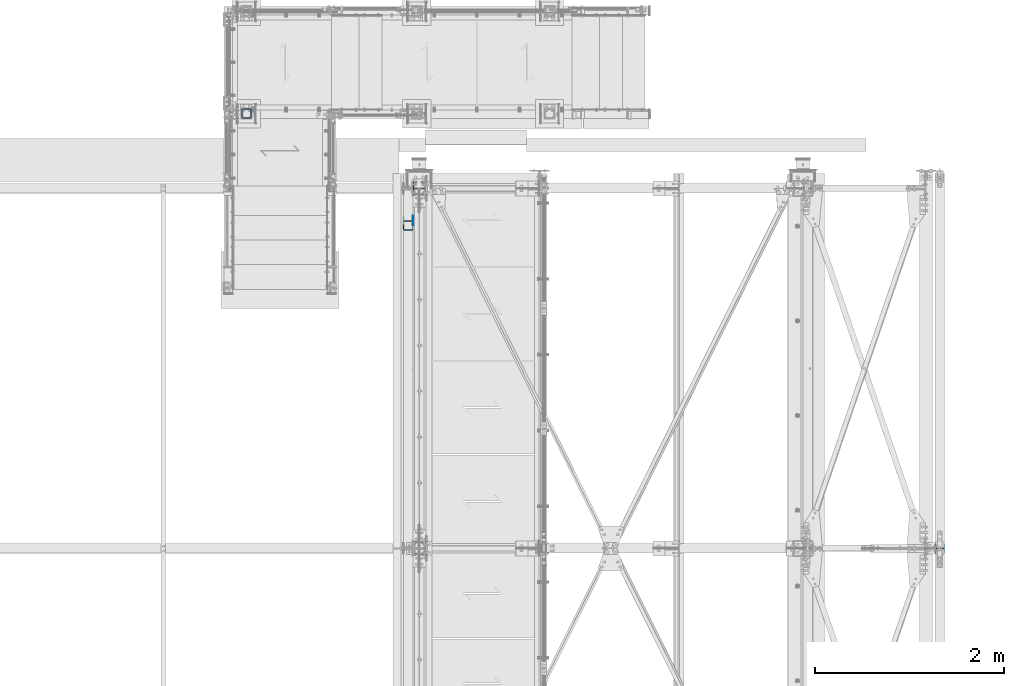
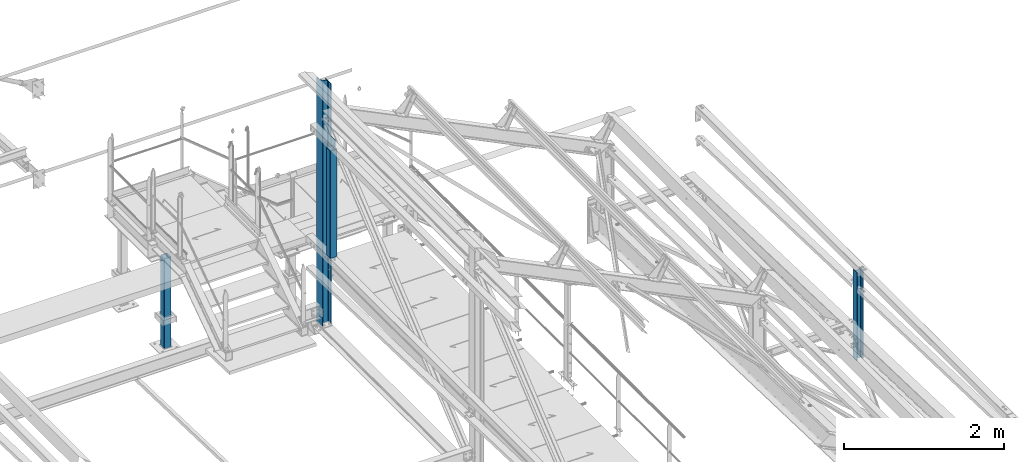
# One storey, part 18 of 496: 5 columns, 4 elements without a shape of their own.
"""IFC2X3 building model written with IfcOpenShell, lengths in millimetres."""

from ifc_helpers import new_model, si_unit, frame, origin_with_axes, origin_2d_with_axis, place, context, subcontext, project, spatial, rectangle, hollow_rectangle, i_section, extrude, clip, halfspace, material, type_object, element, aggregate, save


model = new_model("IFC2X3")

# Units and contexts
model_context = context("Model", 3, precision=1e-05, world=origin_with_axes())
body_context = subcontext(model_context, "Body", "Model", "MODEL_VIEW")
ifc_project = project(units=[si_unit("LENGTHUNIT", "METRE", prefix="MILLI"), si_unit("AREAUNIT", "SQUARE_METRE"), si_unit("VOLUMEUNIT", "CUBIC_METRE"), si_unit("MASSUNIT", "GRAM", prefix="KILO"), si_unit("TIMEUNIT", "SECOND"), si_unit("PLANEANGLEUNIT", "RADIAN"), si_unit("SOLIDANGLEUNIT", "STERADIAN"), si_unit("THERMODYNAMICTEMPERATUREUNIT", "DEGREE_CELSIUS"), si_unit("LUMINOUSINTENSITYUNIT", "LUMEN")], contexts=[model_context])

# Site, building, storey
site_placement = place(None, origin_with_axes())
site = spatial("IfcSite", under=ifc_project, at=site_placement, CompositionType="ELEMENT")
building_placement = place(site_placement, origin_with_axes())
building = spatial("IfcBuilding", under=site, at=building_placement, Name="Undefined", CompositionType="ELEMENT")
storey_placement = place(building_placement, origin_with_axes())
storey = spatial("IfcBuildingStorey", under=building, at=storey_placement, Name="Undefined", CompositionType="ELEMENT", Elevation=0.0)

# Assembly, column
assembly_1_placement = place(storey_placement, origin_with_axes())
assembly_1 = element("IfcElementAssembly", 1, at=assembly_1_placement, inside=storey, AssemblyPlace="NOTDEFINED", PredefinedType="NOTDEFINED")
ifc_material_1 = material(Name="Undefined/S235-E24")
column_type_1 = type_object("IfcColumnType", PredefinedType="NOTDEFINED")
column_1_placement = place(assembly_1_placement, frame((32455.0000000001, 15989.9999136253, 7062.0), z_axis=(0.0, 0.0, 1.0), x_axis=(0.0, 1.0, 0.0)))
column_1 = element("IfcColumn", 2, at=column_1_placement, type_object=column_type_1, material=ifc_material_1, context=body_context, shape_type="SweptSolid", body=[
    extrude(hollow_rectangle(XDim=100.0, YDim=100.0, WallThickness=5.0, InnerFilletRadius=5.0, OuterFilletRadius=10.0, at=origin_2d_with_axis()), frame((0.0, 0.0, 1370.00011661134), z_axis=(0.0, 0.0, -1.0), x_axis=(0.0, 1.0, 0.0)), (0.0, 0.0, 1.0), 1370.0),
])
aggregate(assembly_1, [column_1])

assembly_2_placement = place(storey_placement, origin_with_axes())
assembly_2 = element("IfcElementAssembly", 3, at=assembly_2_placement, inside=storey, Name="MONTANT", AssemblyPlace="NOTDEFINED", PredefinedType="NOTDEFINED")
column_type_2 = type_object("IfcColumnType", PredefinedType="NOTDEFINED")
column_2_placement = place(assembly_2_placement, frame((34163.5000106229, 14810.0001581517, 8555.00000000001), z_axis=(0.0, 0.0, 1.0), x_axis=(0.0, 1.0, 0.0)))
column_2 = element("IfcColumn", 4, at=column_2_placement, type_object=column_type_2, material=ifc_material_1, Name="MONTANT", context=body_context, shape_type="SweptSolid", body=[
    extrude(hollow_rectangle(XDim=100.0, YDim=100.0, WallThickness=4.0, InnerFilletRadius=4.0, OuterFilletRadius=8.0, at=origin_2d_with_axis()), frame((0.0, 0.0, 1635.0), z_axis=(0.0, 0.0, -1.0), x_axis=(0.0, 1.0, 0.0)), (0.0, 0.0, 1.0), 1635.0),
])

assembly_3_placement = place(storey_placement, origin_with_axes())
assembly_3 = element("IfcElementAssembly", 5, at=assembly_3_placement, inside=storey, Name="MONTANT", AssemblyPlace="NOTDEFINED", PredefinedType="NOTDEFINED")
ifc_material_2 = material(Name="Undefined/S275-E28")
column_type_3 = type_object("IfcColumnType", Name="HEA140", PredefinedType="NOTDEFINED")
column_3_placement = place(assembly_3_placement, frame((34280.0, 15200.0, 7260.0), z_axis=(0.0, 0.0, 1.0), x_axis=(-1.0, 0.0, 0.0)))
column_3 = element("IfcColumn", 6, at=column_3_placement, type_object=column_type_3, material=ifc_material_2, Name="MONTANT", ObjectType="HEA140", context=body_context, shape_type="Clipping", body=[
    clip(extrude(i_section(OverallWidth=140.0, OverallDepth=133.0, WebThickness=5.5, FlangeThickness=8.5, FilletRadius=12.0, at=origin_2d_with_axis()), frame((0.0, 0.0, 3730.84210522584), z_axis=(0.0, 0.0, -1.0), x_axis=(0.0, 1.0, 0.0)), (0.0, 0.0, 1.0), 3730.84), halfspace(frame((-66.5, 70.0, 3654.3071165161), z_axis=(-0.441220937981244, -6.28179308850765e-09, 0.89739850896185), x_axis=(0.89739850896185, 0.0, 0.441220937981244)), False)),
])
aggregate(assembly_3, [column_3])

assembly_4_placement = place(storey_placement, origin_with_axes())
assembly_4 = element("IfcElementAssembly", 7, at=assembly_4_placement, inside=storey, AssemblyPlace="NOTDEFINED", PredefinedType="NOTDEFINED")
column_type_4 = type_object("IfcColumnType", Name="HEA100", PredefinedType="NOTDEFINED")
column_4_placement = place(assembly_4_placement, frame((39777.0, 11399.9999999731, 7100.00252984107), z_axis=(0.0, 0.0, 1.0), x_axis=(1.0, 0.0, 0.0)))
column_4 = element("IfcColumn", 8, at=column_4_placement, type_object=column_type_4, material=ifc_material_2, ObjectType="HEA100", context=body_context, shape_type="SweptSolid", body=[
    extrude(i_section(OverallWidth=100.0, OverallDepth=96.0, WebThickness=5.0, FlangeThickness=8.0, FilletRadius=12.0, at=origin_2d_with_axis()), frame((0.0, 0.0, 1344.99747015972), z_axis=(0.0, 0.0, -1.0), x_axis=(0.0, 1.0, 0.0)), (0.0, 0.0, 1.0), 1345.0),
])
aggregate(assembly_4, [column_4])

# Column
column_type_5 = type_object("IfcColumnType", PredefinedType="NOTDEFINED")
column_5_placement = place(assembly_2_placement, frame((34215.9998943307, 14860.0001581517, 8450.0), z_axis=(0.0, 0.0, 1.0), x_axis=(0.0, 1.0, 0.0)))
column_5 = element("IfcColumn", 9, at=column_5_placement, type_object=column_type_5, material=ifc_material_1, context=body_context, shape_type="SweptSolid", body=[
    extrude(rectangle(XDim=5.0, YDim=100.0, at=origin_2d_with_axis()), frame((0.0, 0.0, 1845.0), z_axis=(0.0, 0.0, -1.0), x_axis=(0.0, 1.0, 0.0)), (0.0, 0.0, 1.0), 1845.0),
])

aggregate(assembly_2, [column_5, column_2])

save(model, "model.ifc")
